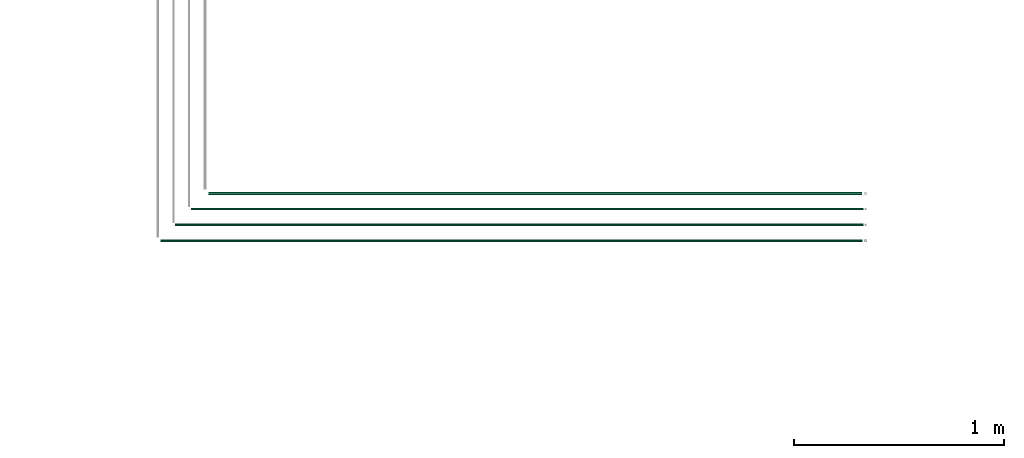
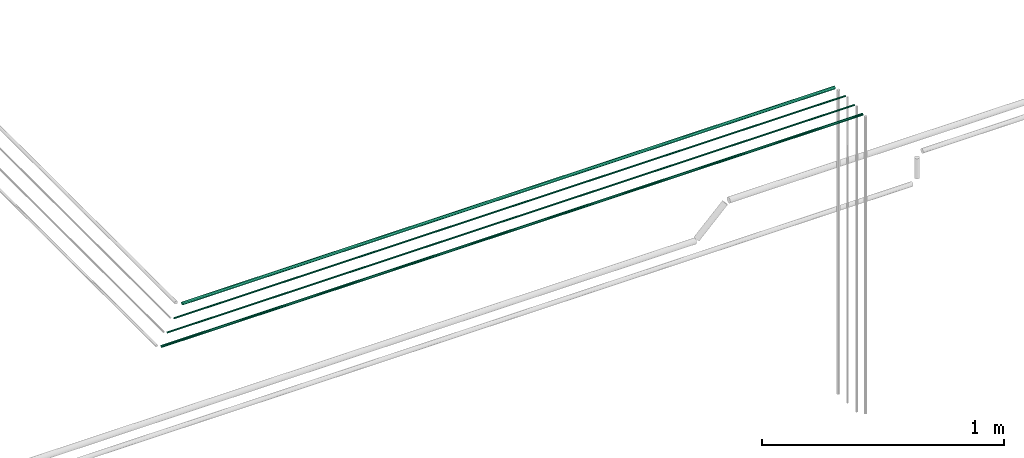
# One storey, part 6 of 331: 4 flow segments.
"""IFC2X3 building model written with IfcOpenShell, lengths in millimetres."""

from ifc_helpers import new_model, entity, si_unit, converted_unit, derived_unit, direction, frame, frame_2d, origin, origin_2d_with_axis, place, context, subcontext, project, spatial, circle, extrude, type_object, element, save


model = new_model("IFC2X3")

# Units and contexts
model_context = context("Model", 3, precision=0.01, world=origin(), true_north=direction((6.12303176911189e-17, 1.0)))
body_context = subcontext(model_context, "Body", "Model", "MODEL_VIEW")
ifc_project = project(units=[si_unit("LENGTHUNIT", "METRE", prefix="MILLI"), si_unit("AREAUNIT", "SQUARE_METRE"), si_unit("VOLUMEUNIT", "CUBIC_METRE"), converted_unit("PLANEANGLEUNIT", "DEGREE", entity("IfcRatioMeasure", 0.0174532925199433), si_unit("PLANEANGLEUNIT", "RADIAN"), dimensions=[0, 0, 0, 0, 0, 0, 0]), si_unit("MASSUNIT", "GRAM", prefix="KILO"), derived_unit("MASSDENSITYUNIT", [(si_unit("MASSUNIT", "GRAM", prefix="KILO"), 1), (si_unit("LENGTHUNIT", "METRE"), -3)]), derived_unit("MOMENTOFINERTIAUNIT", [(si_unit("LENGTHUNIT", "METRE"), 4)]), si_unit("TIMEUNIT", "SECOND"), si_unit("FREQUENCYUNIT", "HERTZ"), si_unit("THERMODYNAMICTEMPERATUREUNIT", "DEGREE_CELSIUS"), derived_unit("THERMALTRANSMITTANCEUNIT", [(si_unit("MASSUNIT", "GRAM", prefix="KILO"), 1), (si_unit("THERMODYNAMICTEMPERATUREUNIT", "KELVIN"), -1), (si_unit("TIMEUNIT", "SECOND"), -3)]), derived_unit("VOLUMETRICFLOWRATEUNIT", [(si_unit("LENGTHUNIT", "METRE"), 3), (si_unit("TIMEUNIT", "SECOND"), -1)]), derived_unit("MASSFLOWRATEUNIT", [(si_unit("MASSUNIT", "GRAM", prefix="KILO"), 1), (si_unit("TIMEUNIT", "SECOND"), -1)]), derived_unit("ROTATIONALFREQUENCYUNIT", [(si_unit("TIMEUNIT", "SECOND"), -1)]), si_unit("ELECTRICCURRENTUNIT", "AMPERE"), si_unit("ELECTRICVOLTAGEUNIT", "VOLT"), si_unit("POWERUNIT", "WATT"), si_unit("FORCEUNIT", "NEWTON", prefix="KILO"), si_unit("ILLUMINANCEUNIT", "LUX"), si_unit("LUMINOUSFLUXUNIT", "LUMEN"), si_unit("LUMINOUSINTENSITYUNIT", "CANDELA"), derived_unit("USERDEFINED", [(si_unit("MASSUNIT", "GRAM", prefix="KILO"), -1), (si_unit("LENGTHUNIT", "METRE"), -2), (si_unit("TIMEUNIT", "SECOND"), 3), (si_unit("LUMINOUSFLUXUNIT", "LUMEN"), 1)]), derived_unit("LINEARVELOCITYUNIT", [(si_unit("LENGTHUNIT", "METRE"), 1), (si_unit("TIMEUNIT", "SECOND"), -1)]), si_unit("PRESSUREUNIT", "PASCAL"), derived_unit("USERDEFINED", [(si_unit("LENGTHUNIT", "METRE"), -2), (si_unit("MASSUNIT", "GRAM", prefix="KILO"), 1), (si_unit("TIMEUNIT", "SECOND"), -2)]), derived_unit("LINEARFORCEUNIT", [(si_unit("MASSUNIT", "GRAM", prefix="KILO"), 1), (si_unit("LENGTHUNIT", "METRE"), 1), (si_unit("TIMEUNIT", "SECOND"), -2), (si_unit("LENGTHUNIT", "METRE"), -1)]), derived_unit("PLANARFORCEUNIT", [(si_unit("MASSUNIT", "GRAM", prefix="KILO"), 1), (si_unit("LENGTHUNIT", "METRE"), 1), (si_unit("TIMEUNIT", "SECOND"), -2), (si_unit("LENGTHUNIT", "METRE"), -2)])], contexts=[model_context])

# Site, building, storey
site_placement = place(None, frame((0.0, -0.00077364408347762, 0.0)))
site = spatial("IfcSite", under=ifc_project, at=site_placement, CompositionType="ELEMENT")
building_placement = place(site_placement, origin())
building = spatial("IfcBuilding", under=site, at=building_placement, CompositionType="ELEMENT")
storey_placement = place(building_placement, origin())
storey = spatial("IfcBuildingStorey", under=building, at=storey_placement, CompositionType="ELEMENT", Elevation=0.0)

# Flow segments
pipe_segment_type = type_object("IfcPipeSegmentType", PredefinedType="NOTDEFINED")
flow_segment_1_placement = place(storey_placement, frame((29884.0364003983, 3135.27987824968, 7240.90472776414)))
element("IfcFlowSegment", 1, at=flow_segment_1_placement, inside=storey, type_object=pipe_segment_type, context=body_context, shape_type="SweptSolid", body=[
    extrude(circle(Radius=7.5, at=origin_2d_with_axis()), frame((0.0, 9.09527223591582, 9.09527223591636), z_axis=(1.0, 0.0, 0.0), x_axis=(0.0, -1.0, 0.0)), (0.0, 0.0, 1.0), 3113.39029134396),
])
flow_segment_2_placement = place(storey_placement, frame((29801.0364003983, 3063.77987824979, 7244.40472776408)))
element("IfcFlowSegment", 2, at=flow_segment_2_placement, inside=storey, type_object=pipe_segment_type, context=body_context, shape_type="SweptSolid", body=[
    extrude(circle(Radius=4.0, at=origin_2d_with_axis()), frame((0.0, 5.59527223591607, 5.59527223591607), z_axis=(1.0, 0.0, 0.0), x_axis=(0.0, -1.0, 0.0)), (0.0, 0.0, 1.0), 3204.39029134396),
])
flow_segment_3_placement = place(storey_placement, frame((29726.0364003983, 2988.77987824991, 7244.4047277641)))
element("IfcFlowSegment", 3, at=flow_segment_3_placement, inside=storey, type_object=pipe_segment_type, context=body_context, shape_type="SweptSolid", body=[
    extrude(circle(Radius=4.0, at=frame_2d((0.0, -1.08286712929839e-12), x_axis=(1.0, 0.0))), frame((0.0, 5.59527223591607, 5.59527223591499), z_axis=(1.0, 0.0, 0.0), x_axis=(0.0, -1.0, 0.0)), (0.0, 0.0, 1.0), 3279.39029134392),
])
flow_segment_4_placement = place(storey_placement, frame((29655.0364003983, 2911.77987824982, 7242.40472776409)))
element("IfcFlowSegment", 4, at=flow_segment_4_placement, inside=storey, type_object=pipe_segment_type, context=body_context, shape_type="SweptSolid", body=[
    extrude(circle(Radius=6.0, at=frame_2d((1.19656817787472e-10, 0.0), x_axis=(1.0, 0.0))), frame((0.0, 7.59527223603582, 7.59527223591562), z_axis=(1.0, 0.0, 0.0), x_axis=(0.0, 1.0, 0.0)), (0.0, 0.0, 1.0), 3346.39029134391),
])

save(model, "model.ifc")
